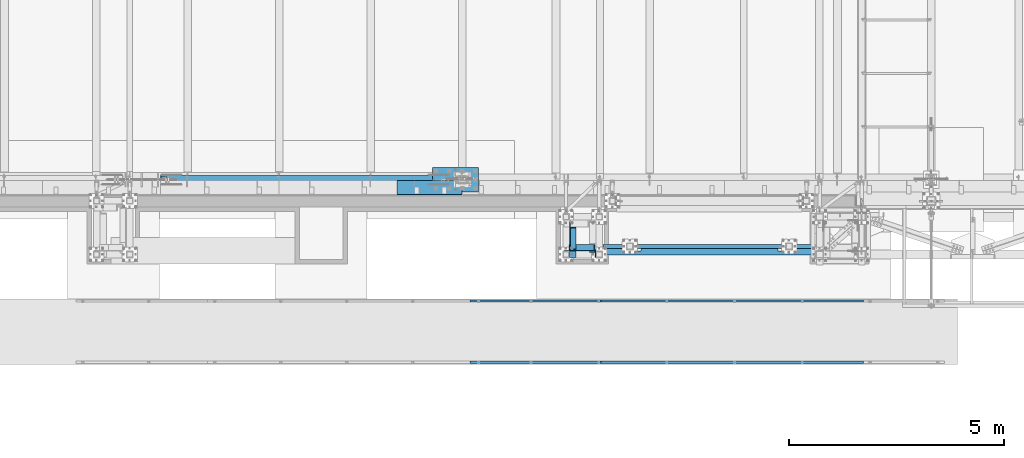
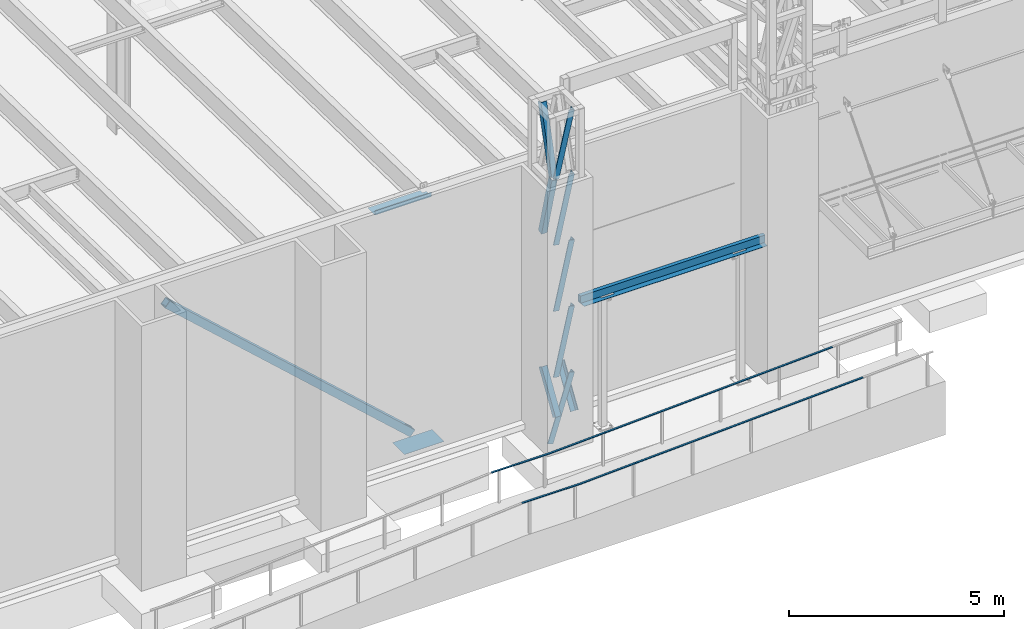
# One storey, part 1038 of 1763: 10 members, 8 beams, 9 elements without a shape of their own.
"""IFC2X3 building model written with IfcOpenShell, lengths in millimetres."""

from ifc_helpers import new_model, si_unit, frame, origin_with_axes, place, context, subcontext, project, spatial, faceted_brep, material, type_object, element, aggregate, save


model = new_model("IFC2X3")

# Units and contexts
model_context = context("Model", 3, precision=1e-05, world=origin_with_axes())
body_context = subcontext(model_context, "Body", "Model", "MODEL_VIEW")
ifc_project = project(units=[si_unit("LENGTHUNIT", "METRE", prefix="MILLI"), si_unit("AREAUNIT", "SQUARE_METRE"), si_unit("VOLUMEUNIT", "CUBIC_METRE"), si_unit("MASSUNIT", "GRAM", prefix="KILO"), si_unit("TIMEUNIT", "SECOND"), si_unit("PLANEANGLEUNIT", "RADIAN"), si_unit("SOLIDANGLEUNIT", "STERADIAN"), si_unit("THERMODYNAMICTEMPERATUREUNIT", "DEGREE_CELSIUS"), si_unit("LUMINOUSINTENSITYUNIT", "LUMEN")], contexts=[model_context])

# Site, building, storey
site_placement = place(None, origin_with_axes())
site = spatial("IfcSite", under=ifc_project, at=site_placement, CompositionType="ELEMENT")
building_placement = place(site_placement, origin_with_axes())
building = spatial("IfcBuilding", under=site, at=building_placement, Name="Undefined", CompositionType="ELEMENT")
storey_placement = place(building_placement, origin_with_axes())
storey = spatial("IfcBuildingStorey", under=building, at=storey_placement, Name="Undefined", CompositionType="ELEMENT", Elevation=0.0)

# Assembly, members
assembly_1_placement = place(storey_placement, origin_with_axes())
assembly_1 = element("IfcElementAssembly", 1, at=assembly_1_placement, inside=storey, Name="FRAME", AssemblyPlace="NOTDEFINED", PredefinedType="RIGID_FRAME")
ifc_material_1 = material(Name="STEEL/A36")
member_type_1 = type_object("IfcMemberType", Name="L6X6X7/8", PredefinedType="NOTDEFINED")
member_1_placement = place(assembly_1_placement, frame((-69925.5694630663, -15268.1723843381, 12563.9140540719), z_axis=(0.0, 0.966292662023721, 0.25744609400632), x_axis=(0.0, 0.25744609400632, -0.966292662023721)))
member_1 = element("IfcMember", 2, at=member_1_placement, type_object=member_type_1, material=ifc_material_1, Name="V. BRACE", ObjectType="L6X6X7/8", context=body_context, shape_type="Brep", body=[
    faceted_brep([(9.09494701772928e-13, -76.2000000000007, -76.2000000000844), (9.09494701772928e-13, 76.2000000000007, -76.2000000000844), (1868.75344729561, 76.1999999999971, -76.1999999992731), (1868.75344729561, -76.1999999999971, -76.1999999992731), (1.81898940354586e-12, -76.2000000000007, -53.9750000000604), (1.81898940354586e-12, 53.9750000000004, -53.9750000000604), (0.0, 53.9750000000004, 76.2000000000771), (0.0, 76.2000000000007, 76.2000000000771), (1868.7534472956, -76.1999999999971, -53.9749999992673), (1868.7534472956, 53.9750000000058, -53.9749999992673), (1868.75344729555, 53.9750000000058, 76.2000000007865), (1868.75344729555, 76.1999999999971, 76.2000000007865)], [[[0, 1, 2, 3]], [[0, 4, 5, 6, 7, 1]], [[5, 4, 8, 9]], [[6, 5, 9, 10]], [[7, 6, 10, 11]], [[1, 7, 11, 2]], [[10, 9, 8, 3, 2, 11]], [[4, 0, 3, 8]]]),
])
member_2_placement = place(assembly_1_placement, frame((-69925.5694630663, -14764.0657847119, 14438.0001145439), z_axis=(0.0, 0.963857514375967, -0.266418265103921), x_axis=(0.0, -0.266418265103921, -0.963857514375967)))
member_2 = element("IfcMember", 3, at=member_2_placement, type_object=member_type_1, material=ifc_material_1, Name="V. BRACE", ObjectType="L6X6X7/8", context=body_context, shape_type="Brep", body=[
    faceted_brep([(9.09494701772928e-13, -76.2000000000007, -76.2000000000844), (9.09494701772928e-13, 76.2000000000007, -76.2000000000844), (1892.74960718638, 76.1999999999971, -76.2000000004191), (1892.74960718638, -76.1999999999971, -76.2000000004191), (1.81898940354586e-12, -76.2000000000007, -53.9750000000604), (1.81898940354586e-12, 53.9750000000004, -53.9750000000604), (0.0, 53.9750000000004, 76.2000000000771), (0.0, 76.2000000000007, 76.2000000000771), (1892.74960718638, -76.1999999999971, -53.9750000004096), (1892.74960718638, 53.9750000000058, -53.9750000004096), (1892.74960718641, 53.9750000000058, 76.1999999996406), (1892.74960718641, 76.1999999999971, 76.1999999996406)], [[[0, 1, 2, 3]], [[0, 4, 5, 6, 7, 1]], [[5, 4, 8, 9]], [[6, 5, 9, 10]], [[7, 6, 10, 11]], [[1, 7, 11, 2]], [[10, 9, 8, 3, 2, 11]], [[4, 0, 3, 8]]]),
])
member_3_placement = place(assembly_1_placement, frame((-69925.5694630468, -14799.8127112354, 6945.69763129683), z_axis=(-1.90000006114133e-07, 0.846976442016007, -0.531630423010074), x_axis=(1.18999999498545e-07, -0.53163042301006, -0.846976442016028)))
member_3 = element("IfcMember", 4, at=member_3_placement, type_object=member_type_1, material=ifc_material_1, Name="V. BRACE", ObjectType="L6X6X7/8", context=body_context, shape_type="Brep", body=[
    faceted_brep([(9.09494701772928e-13, -76.2000000000007, -76.2000000000844), (9.09494701772928e-13, 76.2000000000007, -76.2000000000844), (1228.13053531922, 76.1999999928375, -76.2000000008793), (1228.1305353191, -76.2000000071712, -76.2000000007974), (1.81898940354586e-12, -76.2000000000007, -53.9750000000604), (1.81898940354586e-12, 53.9750000000004, -53.9750000000604), (0.0, 53.9750000000004, 76.2000000000771), (0.0, 76.2000000000007, 76.2000000000771), (1228.13053531911, -76.2000000070693, -53.9750000008135), (1228.13053531921, 53.9749999929481, -53.9750000008862), (1228.13053531927, 53.9749999934866, 76.1999999990185), (1228.13053531929, 76.1999999934924, 76.1999999990057)], [[[0, 1, 2, 3]], [[0, 4, 5, 6, 7, 1]], [[5, 4, 8, 9]], [[6, 5, 9, 10]], [[7, 6, 10, 11]], [[1, 7, 11, 2]], [[10, 9, 8, 3, 2, 11]], [[4, 0, 3, 8]]]),
])
member_4_placement = place(assembly_1_placement, frame((-69482.2629590792, -15300.4630615834, 12588.8749998533), z_axis=(-0.975768660920604, 0.0, 0.218804753982199), x_axis=(-0.218804753982199, 0.0, -0.975768660920604)))
member_4 = element("IfcMember", 5, at=member_4_placement, type_object=member_type_1, material=ifc_material_1, Name="V. BRACE", ObjectType="L6X6X7/8", context=body_context, shape_type="Brep", body=[
    faceted_brep([(9.09494701772928e-13, 76.2000000000007, -76.2000000000844), (0.0, 76.2000000000007, 76.2000000000771), (1920.5820240066, 76.2000000000007, 76.1999999998516), (1920.58202400652, 76.2000000000007, -76.2000000004628), (0.0, 53.9750000000004, 76.2000000000771), (1920.5820240066, 53.9750000000004, 76.1999999998516), (1.81898940354586e-12, 53.9750000000004, -53.9750000000604), (1920.58202400653, 53.9750000000004, -53.9750000004133), (1.81898940354586e-12, -76.2000000000007, -53.9750000000604), (1920.58202400653, -76.2000000000007, -53.9750000004133), (9.09494701772928e-13, -76.2000000000007, -76.2000000000844), (1920.58202400652, -76.2000000000007, -76.2000000004628)], [[[0, 1, 2, 3]], [[1, 4, 5, 2]], [[4, 6, 7, 5]], [[6, 8, 9, 7]], [[8, 10, 11, 9]], [[10, 0, 3, 11]], [[5, 7, 9, 11, 3, 2]], [[10, 8, 6, 4, 1, 0]]]),
])
member_5_placement = place(assembly_1_placement, frame((-69482.2629590724, -15300.4630615834, 10714.8312498533), z_axis=(-0.975768660920604, 0.0, 0.218804753982199), x_axis=(-0.218804753982199, 0.0, -0.975768660920604)))
member_5 = element("IfcMember", 6, at=member_5_placement, type_object=member_type_1, material=ifc_material_1, Name="V. BRACE", ObjectType="L6X6X7/8", context=body_context, shape_type="Brep", body=[
    faceted_brep([(9.09494701772928e-13, 76.2000000000007, -76.2000000000844), (0.0, 76.2000000000007, 76.2000000000771), (1920.5820240066, 76.2000000000007, 76.1999999998516), (1920.58202400652, 76.2000000000007, -76.2000000004628), (0.0, 53.9750000000004, 76.2000000000771), (1920.5820240066, 53.9750000000004, 76.1999999998516), (1.81898940354586e-12, 53.9750000000004, -53.9750000000604), (1920.58202400653, 53.9750000000004, -53.9750000004133), (1.81898940354586e-12, -76.2000000000007, -53.9750000000604), (1920.58202400653, -76.2000000000007, -53.9750000004133), (9.09494701772928e-13, -76.2000000000007, -76.2000000000844), (1920.58202400652, -76.2000000000007, -76.2000000004628)], [[[0, 1, 2, 3]], [[1, 4, 5, 2]], [[4, 6, 7, 5]], [[6, 8, 9, 7]], [[8, 10, 11, 9]], [[10, 0, 3, 11]], [[5, 7, 9, 11, 3, 2]], [[10, 8, 6, 4, 1, 0]]]),
])
member_6_placement = place(assembly_1_placement, frame((-69482.1268418951, -15300.4630615834, 14401.8000002024), z_axis=(-0.974137606436103, 0.0, 0.225955579101161), x_axis=(-0.225955579101159, 0.0, -0.974137606436103)))
member_6 = element("IfcMember", 7, at=member_6_placement, type_object=member_type_1, material=ifc_material_1, Name="V. BRACE", ObjectType="L6X6X7/8", context=body_context, shape_type="Brep", body=[
    faceted_brep([(9.09494701772928e-13, 76.2000000000007, -76.2000000000844), (0.0, 76.2000000000007, 76.2000000000771), (1861.05637242494, 76.2000000000007, 76.1999999891268), (1861.05637242493, 76.2000000000007, -76.2000000105327), (0.0, 53.9750000000004, 76.2000000000771), (1861.05637242494, 53.9750000000004, 76.1999999891268), (1.81898940354586e-12, 53.9750000000004, -53.9750000000604), (1861.05637242493, 53.9750000000004, -53.9750000105851), (1.81898940354586e-12, -76.2000000000007, -53.9750000000604), (1861.05637242493, -76.2000000000007, -53.9750000105851), (9.09494701772928e-13, -76.2000000000007, -76.2000000000844), (1861.05637242493, -76.2000000000007, -76.2000000105327)], [[[0, 1, 2, 3]], [[1, 4, 5, 2]], [[4, 6, 7, 5]], [[6, 8, 9, 7]], [[8, 10, 11, 9]], [[10, 0, 3, 11]], [[5, 7, 9, 11, 3, 2]], [[10, 8, 6, 4, 1, 0]]]),
])
member_7_placement = place(assembly_1_placement, frame((-69482.2629590656, -15300.4630615834, 8840.78749985332), z_axis=(-0.975768660920604, 0.0, 0.218804753982199), x_axis=(-0.218804753982199, 0.0, -0.975768660920604)))
member_7 = element("IfcMember", 8, at=member_7_placement, type_object=member_type_1, material=ifc_material_1, Name="V. BRACE", ObjectType="L6X6X7/8", context=body_context, shape_type="Brep", body=[
    faceted_brep([(9.09494701772928e-13, 76.2000000000007, -76.2000000000844), (0.0, 76.2000000000007, 76.2000000000771), (1920.5820240066, 76.2000000000007, 76.1999999998516), (1920.58202400652, 76.2000000000007, -76.2000000004628), (0.0, 53.9750000000004, 76.2000000000771), (1920.5820240066, 53.9750000000004, 76.1999999998516), (1.81898940354586e-12, 53.9750000000004, -53.9750000000604), (1920.58202400653, 53.9750000000004, -53.9750000004133), (1.81898940354586e-12, -76.2000000000007, -53.9750000000604), (1920.58202400653, -76.2000000000007, -53.9750000004133), (9.09494701772928e-13, -76.2000000000007, -76.2000000000844), (1920.58202400652, -76.2000000000007, -76.2000000004628)], [[[0, 1, 2, 3]], [[1, 4, 5, 2]], [[4, 6, 7, 5]], [[6, 8, 9, 7]], [[8, 10, 11, 9]], [[10, 0, 3, 11]], [[5, 7, 9, 11, 3, 2]], [[10, 8, 6, 4, 1, 0]]]),
])
member_8_placement = place(assembly_1_placement, frame((-69480.5456740028, -15300.4630615834, 6966.74375009278), z_axis=(-0.953918533796507, 0.0, 0.300065710935991), x_axis=(-0.300065710935989, 0.0, -0.953918533796508)))
member_8 = element("IfcMember", 9, at=member_8_placement, type_object=member_type_1, material=ifc_material_1, Name="V. BRACE", ObjectType="L6X6X7/8", context=body_context, shape_type="Brep", body=[
    faceted_brep([(9.09494701772928e-13, 76.2000000000007, -76.2000000000844), (0.0, 76.2000000000007, 76.2000000000771), (1927.29114476475, 76.2000000000007, 76.2000000015396), (1927.29114476478, 76.2000000000007, -76.1999999978871), (0.0, 53.9750000000004, 76.2000000000771), (1927.29114476475, 53.9750000000004, 76.2000000015396), (1.81898940354586e-12, 53.9750000000004, -53.9750000000604), (1927.29114476478, 53.9750000000004, -53.974999997954), (1.81898940354586e-12, -76.2000000000007, -53.9750000000604), (1927.29114476478, -76.2000000000007, -53.974999997954), (9.09494701772928e-13, -76.2000000000007, -76.2000000000844), (1927.29114476478, -76.2000000000007, -76.1999999978871)], [[[0, 1, 2, 3]], [[1, 4, 5, 2]], [[4, 6, 7, 5]], [[6, 8, 9, 7]], [[8, 10, 11, 9]], [[10, 0, 3, 11]], [[5, 7, 9, 11, 3, 2]], [[10, 8, 6, 4, 1, 0]]]),
])
member_9_placement = place(assembly_1_placement, frame((-69458.9118357646, -15452.7242669931, 5905.50000000661), z_axis=(-1.0, 0.0, 0.0), x_axis=(1.18999999498545e-07, 0.53163042301006, 0.846976442016028)))
member_9 = element("IfcMember", 10, at=member_9_placement, type_object=member_type_1, material=ifc_material_1, Name="V. BRACE", ObjectType="L6X6X7/8", context=body_context, shape_type="Brep", body=[
    faceted_brep([(9.09494701772928e-13, -76.2000000000007, -76.2000000000844), (9.09494701772928e-13, 76.2000000000007, -76.2000000000844), (1228.13053531922, 76.1999999928375, -76.2000000008793), (1228.1305353191, -76.2000000071712, -76.2000000007974), (1.81898940354586e-12, -76.2000000000007, -53.9750000000604), (1.81898940354586e-12, 53.9750000000004, -53.9750000000604), (0.0, 53.9750000000004, 76.2000000000771), (0.0, 76.2000000000007, 76.2000000000771), (1228.13053531911, -76.2000000070693, -53.9750000008135), (1228.13053531921, 53.9749999929481, -53.9750000008862), (1228.13053531927, 53.9749999934866, 76.1999999990185), (1228.13053531929, 76.1999999934924, 76.1999999990057)], [[[0, 1, 2, 3]], [[0, 4, 5, 6, 7, 1]], [[5, 4, 8, 9]], [[6, 5, 9, 10]], [[7, 6, 10, 11]], [[1, 7, 11, 2]], [[10, 9, 8, 3, 2, 11]], [[4, 0, 3, 8]]]),
])
aggregate(assembly_1, [member_1, member_2, member_3, member_4, member_5, member_6, member_7, member_8, member_9])

# Assembly, beam
assembly_2_placement = place(storey_placement, origin_with_axes())
assembly_2 = element("IfcElementAssembly", 11, at=assembly_2_placement, inside=storey, Name="HANDRAIL", AssemblyPlace="NOTDEFINED", PredefinedType="RIGID_FRAME")
beam_type_1 = type_object("IfcBeamType", PredefinedType="NOTDEFINED")
beam_1_placement = place(assembly_2_placement, frame((-69266.3544174921, -17957.80011631, 5882.09958929361), z_axis=(0.0, 1.0, 0.0), x_axis=(0.998862153652615, 0.0, 0.0476906489834141)))
beam_1 = element("IfcBeam", 12, at=beam_1_placement, type_object=beam_type_1, material=ifc_material_1, Name="HANDRAIL", context=body_context, shape_type="Brep", body=[
    faceted_brep([(-5.82076609134674e-11, 9.52499999999418, -25.4000000000015), (-5.82076609134674e-11, 9.52499999999418, 25.4000000000015), (6102.94421280013, 9.52500000077271, 25.4000000000015), (6102.94421280013, 9.52500000077271, -25.4000000000015), (2.91038304567337e-11, -9.52499999999418, 25.4000000000015), (6102.94421280023, -9.52499999921383, 25.4000000000015), (2.91038304567337e-11, -9.52499999999418, -25.4000000000015), (6102.94421280023, -9.52499999921383, -25.4000000000015)], [[[0, 1, 2, 3]], [[1, 4, 5, 2]], [[4, 6, 7, 5]], [[6, 0, 3, 7]], [[5, 7, 3, 2]], [[6, 4, 1, 0]]]),
])
aggregate(assembly_2, [beam_1])

assembly_3_placement = place(storey_placement, origin_with_axes())
assembly_3 = element("IfcElementAssembly", 13, at=assembly_3_placement, inside=storey, Name="HANDRAIL", AssemblyPlace="NOTDEFINED", PredefinedType="RIGID_FRAME")
beam_2_placement = place(assembly_3_placement, frame((-72314.0559478679, -17957.80011631, 5807.70057154442), z_axis=(0.0, 1.0, 0.0), x_axis=(0.996872552035352, 0.0, 0.0790260400027984)))
beam_2 = element("IfcBeam", 14, at=beam_2_placement, type_object=beam_type_1, material=ifc_material_1, Name="HANDRAIL", context=body_context, shape_type="Brep", body=[
    faceted_brep([(2.91038304567337e-11, -9.52499999999418, -25.4000000000015), (2.91038304567337e-11, -9.52499999999418, 25.4000000000015), (-5.82076609134674e-11, 9.52499999999418, 25.4000000000015), (-5.82076609134674e-11, 9.52499999999418, -25.4000000000015), (51.7190752267925, 9.52500000303371, 25.4000000000015), (51.7190752267925, 9.52500000303371, -25.4000000000015), (52.4729441398522, -9.52499999693828, -25.4000000000015), (52.4729441398522, -9.52499999693828, 25.4000000000015), (1570.65261763094, 129.931595488508, 25.4000000000015), (1570.65261763094, 129.931595488508, -25.4000000000015), (1571.70494016079, 110.905254050878, -25.4000000000015), (1571.70494016079, 110.905254050878, 25.4000000000015), (3043.75042841214, 176.201749202375, 25.4000000000015), (3043.75042841214, 176.201749202375, -25.4000000000015), (3044.34849591856, 157.161139567748, 25.4000000000015), (3044.34849591856, 157.161139567748, -25.4000000000015)], [[[0, 1, 2, 3]], [[3, 2, 4, 5]], [[1, 0, 6, 7]], [[5, 4, 8, 9]], [[7, 6, 10, 11]], [[9, 8, 12, 13]], [[8, 4, 2, 1, 7, 11, 14, 12]], [[11, 10, 15, 14]], [[10, 6, 0, 3, 5, 9, 13, 15]], [[14, 15, 13, 12]]]),
])
aggregate(assembly_3, [beam_2])

assembly_4_placement = place(storey_placement, origin_with_axes())
assembly_4 = element("IfcElementAssembly", 15, at=assembly_4_placement, inside=storey, Name="HANDRAIL", AssemblyPlace="NOTDEFINED", PredefinedType="RIGID_FRAME")
beam_3_placement = place(assembly_4_placement, frame((-69266.3544174921, -16535.40011631, 5882.09958929361), z_axis=(0.0, 1.0, 0.0), x_axis=(0.998862153652615, 0.0, 0.0476906489834141)))
beam_3 = element("IfcBeam", 16, at=beam_3_placement, type_object=beam_type_1, material=ifc_material_1, Name="HANDRAIL", context=body_context, shape_type="Brep", body=[
    faceted_brep([(-5.82076609134674e-11, 9.52499999999418, -25.4000000000015), (-5.82076609134674e-11, 9.52499999999418, 25.4000000000015), (6102.94421280013, 9.52500000077271, 25.4000000000015), (6102.94421280013, 9.52500000077271, -25.4000000000015), (2.91038304567337e-11, -9.52499999999418, 25.4000000000015), (6102.94421280023, -9.52499999921383, 25.4000000000015), (2.91038304567337e-11, -9.52499999999418, -25.4000000000015), (6102.94421280023, -9.52499999921383, -25.4000000000015)], [[[0, 1, 2, 3]], [[1, 4, 5, 2]], [[4, 6, 7, 5]], [[6, 0, 3, 7]], [[5, 7, 3, 2]], [[6, 4, 1, 0]]]),
])
aggregate(assembly_4, [beam_3])

assembly_5_placement = place(storey_placement, origin_with_axes())
assembly_5 = element("IfcElementAssembly", 17, at=assembly_5_placement, inside=storey, Name="HANDRAIL", AssemblyPlace="NOTDEFINED", PredefinedType="RIGID_FRAME")
beam_4_placement = place(assembly_5_placement, frame((-72314.0559478679, -16535.40011631, 5807.70057154442), z_axis=(0.0, 1.0, 0.0), x_axis=(0.996872552035352, 0.0, 0.0790260400027984)))
beam_4 = element("IfcBeam", 18, at=beam_4_placement, type_object=beam_type_1, material=ifc_material_1, Name="HANDRAIL", context=body_context, shape_type="Brep", body=[
    faceted_brep([(2.91038304567337e-11, -9.52499999999418, -25.4000000000015), (2.91038304567337e-11, -9.52499999999418, 25.4000000000015), (-5.82076609134674e-11, 9.52499999999418, 25.4000000000015), (-5.82076609134674e-11, 9.52499999999418, -25.4000000000015), (51.7190752267925, 9.52500000303371, 25.4000000000015), (51.7190752267925, 9.52500000303371, -25.4000000000015), (52.4729441398522, -9.52499999693828, -25.4000000000015), (52.4729441398522, -9.52499999693828, 25.4000000000015), (1570.65261763094, 129.931595488508, 25.4000000000015), (1570.65261763094, 129.931595488508, -25.4000000000015), (1571.70494016079, 110.905254050878, -25.4000000000015), (1571.70494016079, 110.905254050878, 25.4000000000015), (3043.75042841214, 176.201749202375, 25.4000000000015), (3043.75042841214, 176.201749202375, -25.4000000000015), (3044.34849591856, 157.161139567748, 25.4000000000015), (3044.34849591856, 157.161139567748, -25.4000000000015)], [[[0, 1, 2, 3]], [[3, 2, 4, 5]], [[1, 0, 6, 7]], [[5, 4, 8, 9]], [[7, 6, 10, 11]], [[9, 8, 12, 13]], [[8, 4, 2, 1, 7, 11, 14, 12]], [[11, 10, 15, 14]], [[10, 6, 0, 3, 5, 9, 13, 15]], [[14, 15, 13, 12]]]),
])
aggregate(assembly_5, [beam_4])

# Assembly, beams
assembly_6_placement = place(storey_placement, origin_with_axes())
assembly_6 = element("IfcElementAssembly", 19, at=assembly_6_placement, inside=storey, Name="BEAM", AssemblyPlace="NOTDEFINED", PredefinedType="RIGID_FRAME")
beam_type_2 = type_object("IfcBeamType", PredefinedType="NOTDEFINED")
beam_5_placement = place(assembly_6_placement, frame((-69204.9116896589, -15351.1250613784, 8783.6375), z_axis=(0.0, 1.0, 0.0), x_axis=(1.0, 0.0, 0.0)))
beam_5 = element("IfcBeam", 20, at=beam_5_placement, type_object=beam_type_2, material=ifc_material_1, Name="PLATE", context=body_context, shape_type="Brep", body=[
    faceted_brep([(4054.47363319391, -4.76249999999891, 111.125), (4054.47363319391, -4.76250000000073, -15.8750000000055), (4054.47363319391, 4.76250000000073, -15.8750000000055), (4054.47363319391, 4.76250000000073, 111.125), (4410.07363319392, -4.76250000000073, -15.8750000000055), (4410.07363319392, 4.76250000000073, -15.8750000000055), (4410.07363319392, -4.76250000000073, 111.125), (4410.07363319392, 4.76250000000073, 111.125), (863.600000381426, -4.76249999999709, 111.125), (863.600000381426, 4.76250000000073, 111.125), (863.600000381426, 4.76250000000073, -15.8750000000109), (863.600000381426, -4.76249999999709, -15.8750000000109), (508.00000038142, 4.76250000000073, -15.8750000000109), (508.00000038142, -4.76249999999709, -15.8750000000109), (508.00000038142, -4.76250000000073, 111.125), (508.00000038142, 4.76250000000073, 111.125), (0.0, 4.76250000000073, 111.125), (0.0, -4.76250000000073, 111.125), (0.0, -4.76250000000073, -111.125), (0.0, 4.76250000000073, -111.125), (4918.08389902732, 4.76250000000073, -111.125), (4918.08389902732, -4.76250000000073, -111.125), (4918.08389902732, -4.76250000000073, 111.125), (4918.08389902732, 4.76250000000073, 111.125)], [[[0, 1, 2, 3]], [[4, 5, 2, 1]], [[6, 7, 5, 4]], [[8, 9, 10, 11]], [[11, 10, 12, 13]], [[14, 13, 12, 15]], [[16, 17, 14, 15]], [[18, 17, 16, 19]], [[18, 19, 20, 21]], [[22, 21, 20, 23]], [[1, 0, 8, 11, 13, 14, 17, 18, 21, 22, 6, 4]], [[9, 8, 0, 3]], [[23, 20, 19, 16, 15, 12, 10, 9, 3, 2, 5, 7]], [[22, 23, 7, 6]]]),
])
ifc_material_2 = material()
beam_type_3 = type_object("IfcBeamType", Name="HSS8X4X3/8", PredefinedType="NOTDEFINED")
beam_6_placement = place(assembly_6_placement, frame((-69230.3116892775, -15265.4000613784, 8890.0), z_axis=(0.0, 0.0, 1.0), x_axis=(1.0, 0.0, 0.0)))
beam_6 = element("IfcBeam", 21, at=beam_6_placement, type_object=beam_type_3, material=ifc_material_2, Name="BEAM", ObjectType="HSS8X4X3/8", context=body_context, shape_type="Brep", body=[
    faceted_brep([(6.3500000000131, 41.2749999999996, -92.0750000000007), (6.3500000000131, -41.2749999999996, -92.0750000000007), (4962.53389826443, -41.2749999999996, -92.0750000000007), (4962.53389826443, 41.2749999999996, -92.0750000000007), (6.3500000000131, -41.2749999999996, 92.0750000000007), (4962.53389826443, -41.2749999999996, 92.0750000000007), (6.3500000000131, 41.2749999999996, 92.0750000000007), (4962.53389826443, 41.2749999999996, 92.0750000000007), (6.3500000000131, 50.7999999999993, -101.6), (6.3500000000131, 50.7999999999993, 101.6), (4962.53389826443, 50.7999999999993, 101.6), (4962.53389826443, 50.7999999999993, -101.6), (6.3500000000131, -50.7999999999993, 101.6), (4962.53389826443, -50.7999999999993, 101.6), (6.3500000000131, -50.7999999999993, -101.6), (4962.53389826443, -50.7999999999993, -101.6)], [[[0, 1, 2, 3]], [[1, 4, 5, 2]], [[4, 6, 7, 5]], [[6, 0, 3, 7]], [[8, 9, 10, 11]], [[9, 12, 13, 10]], [[12, 14, 15, 13]], [[14, 8, 11, 15]], [[13, 15, 11, 10], [5, 7, 3, 2]], [[14, 12, 9, 8], [6, 4, 1, 0]]]),
])
aggregate(assembly_6, [beam_5, beam_6])

# Assembly, beam
assembly_7_placement = place(storey_placement, origin_with_axes())
assembly_7 = element("IfcElementAssembly", 22, at=assembly_7_placement, inside=storey, Name="BEAM", AssemblyPlace="NOTDEFINED", PredefinedType="RIGID_FRAME")
beam_type_4 = type_object("IfcBeamType", PredefinedType="NOTDEFINED")
beam_7_placement = place(assembly_7_placement, frame((-73251.4497736983, -13728.6998186171, 12207.875), z_axis=(-1.0, 0.0, 0.0), x_axis=(0.0, -1.0, 0.0)))
beam_7 = element("IfcBeam", 23, at=beam_7_placement, type_object=beam_type_4, material=ifc_material_1, Name="BENT_PLATE", context=body_context, shape_type="Brep", body=[
    faceted_brep([(101.600181382937, -3.17499999999927, -646.112500000017), (101.600181382937, 3.17499999999927, -646.112500000017), (101.600181382933, 3.17499999999927, -757.237500000003), (101.600181382933, -3.17499999999927, -757.237500000003), (0.0, -3.17499999999927, -646.112499999945), (0.0, 3.17499999999927, -646.112499999945), (330.19998779297, 3.17499999999927, 757.237500000003), (0.0, 3.17499999999927, 757.237500000003), (0.0, -3.17499999999927, 757.237500000003), (336.549987792969, -3.17499999999927, 757.237500000003), (336.549987792969, 123.825000000001, 757.237500000003), (330.19998779297, 123.825000000001, 757.237500000003), (330.19998779297, 3.17499999999927, -757.237500000003), (330.19998779297, 123.825000000001, -757.237500000003), (336.549987792969, 123.825000000001, -757.237500000003), (336.549987792969, -3.17499999999927, -757.237500000003)], [[[0, 1, 2, 3]], [[4, 5, 1, 0]], [[6, 7, 8, 9, 10, 11]], [[12, 6, 11, 13]], [[10, 14, 13, 11]], [[9, 15, 14, 10]], [[12, 13, 14, 15, 3, 2]], [[7, 6, 12, 2, 1, 5]], [[8, 7, 5, 4]], [[15, 9, 8, 4, 0, 3]]]),
])
aggregate(assembly_7, [beam_7])

assembly_8_placement = place(storey_placement, origin_with_axes())
assembly_8 = element("IfcElementAssembly", 24, at=assembly_8_placement, inside=storey, Name="TEMPLATE", AssemblyPlace="NOTDEFINED", PredefinedType="RIGID_FRAME")
beam_type_5 = type_object("IfcBeamType", PredefinedType="NOTDEFINED")
beam_8_placement = place(assembly_8_placement, frame((-72643.4372736983, -13995.4, 5083.175), z_axis=(-1.0, 0.0, 0.0), x_axis=(0.0, 1.0, 0.0)))
beam_8 = element("IfcBeam", 25, at=beam_8_placement, type_object=beam_type_5, material=ifc_material_1, Name="TEMPLATE", context=body_context, shape_type="Brep", body=[
    faceted_brep([(0.0, 3.17500000000018, -533.399999999994), (0.0, 3.17500000000018, 533.399999999994), (558.799999999999, 3.17500000000018, 533.399999999994), (558.799999999999, 3.17500000000018, -533.399999999994), (0.0, -3.17500000000018, 533.399999999994), (558.799999999999, -3.17500000000018, 533.399999999994), (0.0, -3.17500000000018, -533.399999999994), (558.799999999999, -3.17500000000018, -533.399999999994)], [[[0, 1, 2, 3]], [[1, 4, 5, 2]], [[4, 6, 7, 5]], [[6, 0, 3, 7]], [[5, 7, 3, 2]], [[6, 4, 1, 0]]]),
])
aggregate(assembly_8, [beam_8])

# Assembly, member
assembly_9_placement = place(storey_placement, origin_with_axes())
assembly_9 = element("IfcElementAssembly", 26, at=assembly_9_placement, inside=storey, Name="V. BRACE", AssemblyPlace="NOTDEFINED", PredefinedType="RIGID_FRAME")
member_type_2 = type_object("IfcMemberType", Name="HSS8X8X1/2", PredefinedType="NOTDEFINED")
member_10_placement = place(assembly_9_placement, frame((-72491.0372736984, -13716.0, 5130.8), z_axis=(0.671476028756224, 0.0, 0.741026276730974), x_axis=(-0.741026276730974, 0.0, 0.671476028756224)))
member_10 = element("IfcMember", 27, at=member_10_placement, type_object=member_type_2, material=ifc_material_2, Name="V. BRACE", ObjectType="HSS8X8X1/2", context=body_context, shape_type="Brep", body=[
    faceted_brep([(9363.56840583179, 11.1125003815287, 101.59999995953), (9058.76840873617, 11.1125003815287, 101.599999960854), (9058.76840873624, 11.1125003815287, 88.8999999608423), (9363.56840583186, 11.1125003815287, 88.8999999595326), (9055.12334918883, 10.387452957737, 101.599999960868), (9055.12334918891, 10.387452957737, 88.8999999608568), (9052.03321691502, 8.32269258406086, 101.599999960883), (9052.03321691509, 8.32269258406086, 88.8999999608714), (9049.96845654132, 5.2325603102945, 101.59999996089), (9049.96845654139, 5.2325603102945, 88.8999999608786), (9049.24340911751, 1.58750076299839, 101.59999996089), (9049.2434091176, 1.58750076299839, 88.8999999608859), (9049.24340911751, -1.5875003817946, 101.59999996089), (9049.2434091176, -1.5875003817946, 88.8999999608859), (9049.96845654132, -5.23255992909253, 101.59999996089), (9049.96845654139, -5.23255992909253, 88.8999999608786), (9052.03321691502, -8.32269220286071, 101.599999960883), (9052.03321691509, -8.32269220286071, 88.8999999608714), (9055.12334918883, -10.387452576535, 101.599999960876), (9055.12334918891, -10.387452576535, 88.8999999608641), (9058.76840873618, -11.1125000003249, 101.599999960854), (9058.76840873626, -11.1125000003249, 88.8999999608423), (9363.56840583179, -11.112499999952, 101.59999995953), (9363.56840583186, -11.112499999952, 88.8999999595326), (9363.56840583285, 11.1125003815287, -88.9000000406304), (9058.76840873736, 11.1125003815287, -88.9000000393062), (9058.76840873745, 11.1125003815287, -101.600000039318), (9363.56840583292, 11.1125003815287, -101.600000040642), (9055.12334919003, 10.387452957737, -88.9000000392916), (9055.12334919011, 10.387452957737, -101.600000039303), (9052.03321691621, 8.32269258406086, -88.9000000392771), (9052.0332169163, 8.32269258406086, -101.600000039289), (9049.96845654253, 5.2325603102945, -88.9000000392771), (9049.9684565426, 5.2325603102945, -101.600000039281), (9049.24340911872, 1.58750076299839, -88.9000000392625), (9049.2434091188, 1.58750076299839, -101.600000039281), (9049.24340911872, -1.5875003817946, -88.9000000392625), (9049.2434091188, -1.5875003817946, -101.600000039281), (9049.96845654253, -5.23255992909253, -88.9000000392771), (9049.9684565426, -5.23255992909253, -101.600000039281), (9052.03321691621, -8.32269220286071, -88.9000000392771), (9052.03321691632, -8.32269220286071, -101.600000039296), (9055.12334919003, -10.387452576535, -88.9000000392916), (9055.12334919012, -10.387452576535, -101.600000039311), (9058.76840873739, -11.1125000003249, -88.9000000393135), (9058.76840873747, -11.1125000003249, -101.600000039318), (9363.56840583285, -11.112499999952, -88.9000000406304), (9363.56840583292, -11.112499999952, -101.600000040642), (491.335163565687, 88.8999999999996, 88.8999999979496), (491.335163566684, 88.8999999999996, -88.9000000022061), (9363.56840583285, 88.8999999999996, -88.9000000406304), (9363.56840583186, 88.8999999999996, 88.8999999595326), (9363.56840583186, -88.8999999999996, 88.8999999595326), (491.335163565687, -88.8999999999996, 88.8999999979496), (491.335163565687, -14.2875000004715, 88.8999999979496), (770.735180400741, -14.2875000004715, 88.8999999967346), (775.595259918846, -13.3207700778839, 88.8999999967127), (779.71543638705, -10.5677561774064, 88.8999999967054), (782.468450287561, -6.44757970925275, 88.8999999966909), (783.435180210166, -1.58750019120635, 88.8999999966836), (783.435180210166, 1.58750095320283, 88.8999999966836), (782.468450287561, 6.44758047124924, 88.8999999966909), (779.71543638705, 10.5677569394029, 88.8999999967054), (775.595259918846, 13.3207708398804, 88.8999999967127), (770.735180400741, 14.287500762468, 88.8999999967346), (491.335163565687, 14.287500762468, 88.8999999979496), (491.335163566684, -88.8999999999996, -88.9000000022061), (9363.56840583285, -88.8999999999996, -88.9000000406304), (491.335163566684, 14.287500762468, -88.9000000022061), (770.735180401964, 14.287500762468, -88.9000000034139), (775.595259920075, 13.3207708398804, -88.9000000034357), (779.715436388287, 10.5677569394029, -88.9000000034503), (782.468450288805, 6.44758047124924, -88.9000000034648), (783.435180211396, 1.58750095320283, -88.9000000034648), (783.435180211396, -1.58750019120635, -88.9000000034648), (782.468450288805, -6.44757970925275, -88.9000000034648), (779.715436388287, -10.5677561774064, -88.9000000034503), (775.595259920075, -13.3207700778839, -88.9000000034357), (770.735180401964, -14.2875000004715, -88.9000000034139), (491.335163566684, -14.2875000004715, -88.9000000022061), (491.335163566757, 14.287500762468, -101.600000002218), (770.735180402058, 14.287500762468, -101.600000003433), (775.595259920163, 13.3207708398804, -101.60000000344), (779.715436388367, 10.5677569394029, -101.600000003462), (782.468450288885, 6.44758047124924, -101.600000003469), (783.435180211483, 1.58750095320283, -101.600000003476), (783.435180211483, -1.58750019120635, -101.600000003476), (782.468450288885, -6.44757970925275, -101.600000003469), (779.715436388367, -10.5677561774064, -101.600000003462), (775.595259920163, -13.3207700778839, -101.60000000344), (770.735180402058, -14.2875000004715, -101.600000003433), (491.335163566757, -14.2875000004715, -101.600000002218), (491.335163566757, -101.6, -101.600000002218), (491.335163565607, -101.6, 101.599999997961), (491.335163565607, -14.2875000004715, 101.599999997961), (770.735180400647, -14.2875000004715, 101.599999996753), (775.595259918759, -13.3207700778839, 101.599999996724), (779.71543638697, -10.5677561774064, 101.599999996703), (782.468450287488, -6.44757970925275, 101.599999996695), (783.435180210079, -1.58750019120635, 101.599999996695), (783.435180210079, 1.58750095320283, 101.599999996695), (782.468450287488, 6.44758047124924, 101.599999996695), (779.71543638697, 10.5677569394029, 101.599999996703), (775.595259918759, 13.3207708398804, 101.599999996724), (770.735180400647, 14.287500762468, 101.599999996753), (491.335163565607, 14.287500762468, 101.599999997961), (491.335163565607, 101.6, 101.599999997961), (491.335163566757, 101.6, -101.600000002218), (9363.56840583179, 101.6, 101.59999995953), (9363.56840583292, 101.6, -101.600000040642), (9363.56840583292, -101.6, -101.600000040642), (9363.56840583179, -101.6, 101.59999995953)], [[[0, 1, 2, 3]], [[4, 5, 2, 1]], [[6, 7, 5, 4]], [[8, 9, 7, 6]], [[10, 11, 9, 8]], [[12, 13, 11, 10]], [[14, 15, 13, 12]], [[16, 17, 15, 14]], [[18, 19, 17, 16]], [[20, 21, 19, 18]], [[22, 23, 21, 20]], [[24, 25, 26, 27]], [[28, 29, 26, 25]], [[30, 31, 29, 28]], [[32, 33, 31, 30]], [[34, 35, 33, 32]], [[36, 37, 35, 34]], [[38, 39, 37, 36]], [[40, 41, 39, 38]], [[42, 43, 41, 40]], [[44, 45, 43, 42]], [[46, 47, 45, 44]], [[48, 49, 50, 51]], [[52, 53, 54, 55, 56, 57, 58, 59, 60, 61, 62, 63, 64, 65, 48, 51, 3, 2, 5, 7, 9, 11, 13, 15, 17, 19, 21, 23]], [[66, 53, 52, 67]], [[42, 40, 38, 36, 34, 32, 30, 28, 25, 24, 50, 49, 68, 69, 70, 71, 72, 73, 74, 75, 76, 77, 78, 79, 66, 67, 46, 44]], [[68, 80, 81, 69]], [[69, 81, 82, 70]], [[70, 82, 83, 71]], [[71, 83, 84, 72]], [[72, 84, 85, 73]], [[73, 85, 86, 74]], [[74, 86, 87, 75]], [[75, 87, 88, 76]], [[76, 88, 89, 77]], [[77, 89, 90, 78]], [[78, 90, 91, 79]], [[53, 66, 79, 91, 92, 93, 94, 54]], [[95, 55, 54, 94]], [[96, 56, 55, 95]], [[97, 57, 56, 96]], [[98, 58, 57, 97]], [[99, 59, 58, 98]], [[100, 60, 59, 99]], [[101, 61, 60, 100]], [[102, 62, 61, 101]], [[103, 63, 62, 102]], [[104, 64, 63, 103]], [[105, 65, 64, 104]], [[106, 107, 80, 68, 49, 48, 65, 105]], [[107, 106, 108, 109]], [[51, 50, 24, 27, 109, 108, 0, 3]], [[110, 92, 91, 90, 89, 88, 87, 86, 85, 84, 83, 82, 81, 80, 107, 109, 27, 26, 29, 31, 33, 35, 37, 39, 41, 43, 45, 47]], [[93, 92, 110, 111]], [[18, 16, 14, 12, 10, 8, 6, 4, 1, 0, 108, 106, 105, 104, 103, 102, 101, 100, 99, 98, 97, 96, 95, 94, 93, 111, 22, 20]], [[111, 110, 47, 46, 67, 52, 23, 22]]]),
])
aggregate(assembly_9, [member_10])

save(model, "model.ifc")
